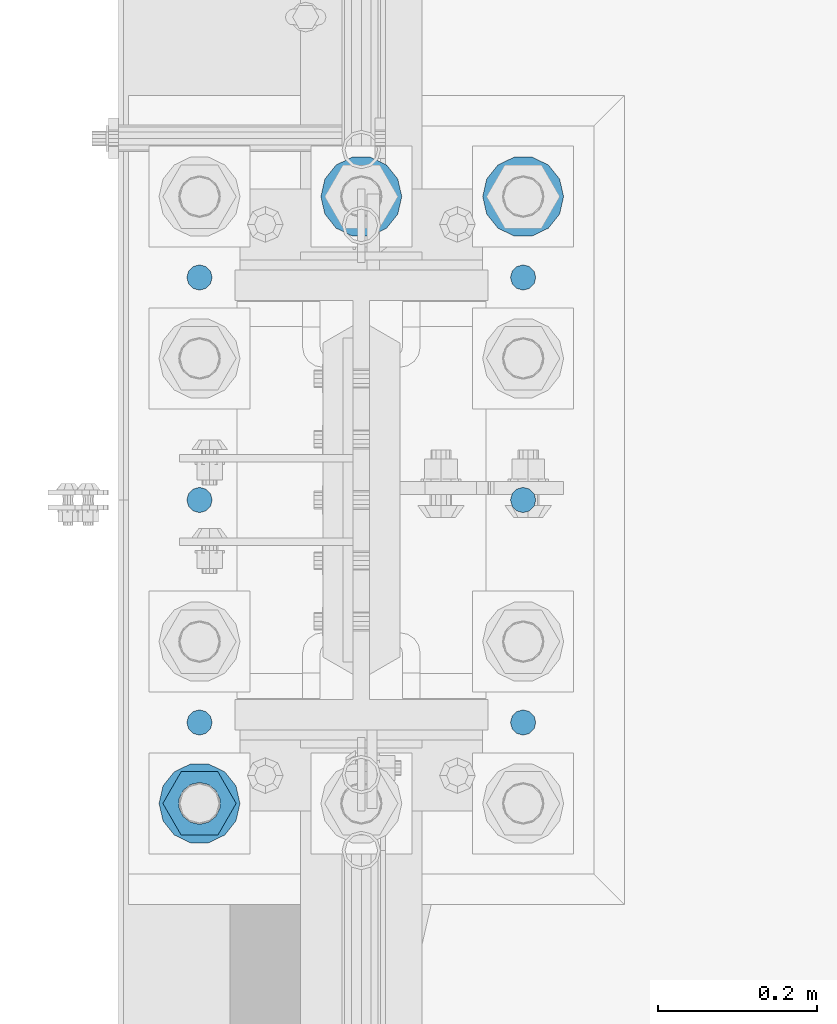
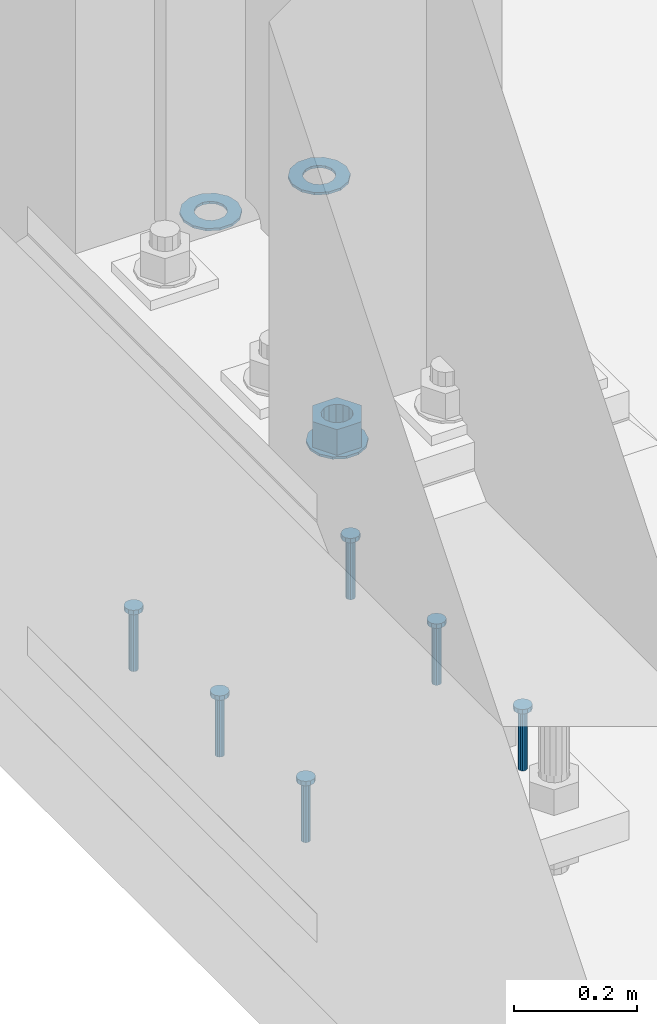
# One storey, part 845 of 1876: 10 columns, 1 element without a shape of its own.
"""IFC2X3 building model written with IfcOpenShell, lengths in millimetres."""

from ifc_helpers import new_model, si_unit, frame, origin_with_axes, place, context, subcontext, project, spatial, faceted_brep, material, type_object, element, aggregate, save


model = new_model("IFC2X3")

# Units and contexts
model_context = context("Model", 3, precision=1e-05, world=origin_with_axes())
body_context = subcontext(model_context, "Body", "Model", "MODEL_VIEW")
ifc_project = project(units=[si_unit("LENGTHUNIT", "METRE", prefix="MILLI"), si_unit("AREAUNIT", "SQUARE_METRE"), si_unit("VOLUMEUNIT", "CUBIC_METRE"), si_unit("MASSUNIT", "GRAM", prefix="KILO"), si_unit("TIMEUNIT", "SECOND"), si_unit("PLANEANGLEUNIT", "RADIAN"), si_unit("SOLIDANGLEUNIT", "STERADIAN"), si_unit("THERMODYNAMICTEMPERATUREUNIT", "DEGREE_CELSIUS"), si_unit("LUMINOUSINTENSITYUNIT", "LUMEN")], contexts=[model_context])

# Site, building, storey
site_placement = place(None, origin_with_axes())
site = spatial("IfcSite", under=ifc_project, at=site_placement, CompositionType="ELEMENT")
building_placement = place(site_placement, origin_with_axes())
building = spatial("IfcBuilding", under=site, at=building_placement, Name="Undefined", CompositionType="ELEMENT")
storey_placement = place(building_placement, origin_with_axes())
storey = spatial("IfcBuildingStorey", under=building, at=storey_placement, Name="Undefined", CompositionType="ELEMENT", Elevation=0.0)

# Assembly, columns
assembly_placement = place(storey_placement, origin_with_axes())
assembly = element("IfcElementAssembly", 1, at=assembly_placement, inside=storey, Name="TEMPLATE", AssemblyPlace="NOTDEFINED", PredefinedType="RIGID_FRAME")
ifc_material_1 = material(Name="STEEL/F436")
column_type_1 = type_object("IfcColumnType", Name="2_WASHER", PredefinedType="NOTDEFINED")
column_1_placement = place(assembly_placement, frame((0.0, 8001.0, 38.1), z_axis=(0.0, -1.0, 0.0), x_axis=(0.0, 0.0, -1.0)))
column_1 = element("IfcColumn", 2, at=column_1_placement, type_object=column_type_1, material=ifc_material_1, Name="WASHER", ObjectType="2_WASHER", context=body_context, shape_type="Brep", body=[
    faceted_brep([(0.0, -50.7999992370605, 9.09494701772928e-13), (0.0, -45.7692178020588, -22.0412936161442), (4.7625, -45.7692178020588, -22.0412936161442), (4.7625, -50.7999992370605, 9.09494701772928e-13), (0.0, -31.6732814587394, -39.7170387128856), (4.7625, -31.6732814587394, -39.7170387128856), (0.0, -11.3040632752118, -49.5263371950259), (4.7625, -11.3040632752118, -49.5263371950259), (0.0, 11.30406327521, -49.5263371950264), (4.7625, 11.30406327521, -49.5263371950264), (0.0, 31.6732814587385, -39.7170387128867), (4.7625, 31.6732814587385, -39.7170387128867), (0.0, 45.7692178020579, -22.041293616146), (4.7625, 45.7692178020579, -22.041293616146), (0.0, 50.7999992370605, -9.09494701772928e-13), (4.7625, 50.7999992370605, -9.09494701772928e-13), (0.0, 45.7692178020588, 22.0412936161442), (4.7625, 45.7692178020588, 22.0412936161442), (0.0, 31.6732814587394, 39.7170387128856), (4.7625, 31.6732814587394, 39.7170387128856), (0.0, 11.3040632752118, 49.5263371950259), (4.7625, 11.3040632752118, 49.5263371950259), (0.0, -11.30406327521, 49.5263371950264), (4.7625, -11.30406327521, 49.5263371950264), (0.0, -31.6732814587385, 39.7170387128867), (4.7625, -31.6732814587385, 39.7170387128867), (0.0, -45.7692178020579, 22.041293616146), (4.7625, -45.7692178020579, 22.041293616146), (0.0, 0.0, 26.9869995117188), (0.0, 11.7093983825444, 24.3146012721213), (4.7625, 11.7093983825444, 24.3146012721213), (4.7625, 0.0, 26.9869995117188), (0.0, 21.0996520289491, 16.8262864224157), (4.7625, 21.0996520289491, 16.8262864224157), (0.0, 26.3108629296712, 6.00524193584533), (4.7625, 26.3108629296712, 6.00524193584533), (0.0, 26.3108629296712, -6.00524193584533), (4.7625, 26.3108629296712, -6.00524193584533), (0.0, 21.0996520289491, -16.8262864224157), (4.7625, 21.0996520289491, -16.8262864224157), (0.0, 11.7093983825444, -24.3146012721213), (4.7625, 11.7093983825444, -24.3146012721213), (0.0, 0.0, -26.9869995117188), (4.7625, 0.0, -26.9869995117188), (0.0, -11.7093983825444, -24.3146012721213), (4.7625, -11.7093983825444, -24.3146012721213), (0.0, -21.0996520289491, -16.8262864224157), (4.7625, -21.0996520289491, -16.8262864224157), (0.0, -26.3108629296712, -6.00524193584533), (4.7625, -26.3108629296712, -6.00524193584533), (0.0, -26.3108629296712, 6.00524193584533), (4.7625, -26.3108629296712, 6.00524193584533), (0.0, -21.0996520289491, 16.8262864224157), (4.7625, -21.0996520289491, 16.8262864224157), (0.0, -11.7093983825444, 24.3146012721213), (4.7625, -11.7093983825444, 24.3146012721213)], [[[0, 1, 2, 3]], [[1, 4, 5, 2]], [[4, 6, 7, 5]], [[6, 8, 9, 7]], [[8, 10, 11, 9]], [[10, 12, 13, 11]], [[12, 14, 15, 13]], [[14, 16, 17, 15]], [[16, 18, 19, 17]], [[18, 20, 21, 19]], [[20, 22, 23, 21]], [[22, 24, 25, 23]], [[24, 26, 27, 25]], [[26, 0, 3, 27]], [[28, 29, 30, 31]], [[29, 32, 33, 30]], [[32, 34, 35, 33]], [[34, 36, 37, 35]], [[36, 38, 39, 37]], [[38, 40, 41, 39]], [[40, 42, 43, 41]], [[42, 44, 45, 43]], [[44, 46, 47, 45]], [[46, 48, 49, 47]], [[48, 50, 51, 49]], [[50, 52, 53, 51]], [[52, 54, 55, 53]], [[54, 28, 31, 55]], [[5, 7, 9, 11, 13, 15, 17, 19, 21, 23, 25, 27, 3, 2], [33, 35, 37, 39, 41, 43, 45, 47, 49, 51, 53, 55, 31, 30]], [[26, 24, 22, 20, 18, 16, 14, 12, 10, 8, 6, 4, 1, 0], [54, 52, 50, 48, 46, 44, 42, 40, 38, 36, 34, 32, 29, 28]]]),
])
column_2_placement = place(assembly_placement, frame((203.2, 8001.0, 38.1), z_axis=(0.0, 1.0, 0.0), x_axis=(0.0, 0.0, -1.0)))
column_2 = element("IfcColumn", 3, at=column_2_placement, type_object=column_type_1, material=ifc_material_1, Name="WASHER", ObjectType="2_WASHER", context=body_context, shape_type="Brep", body=[
    faceted_brep([(0.0, -50.7999992370605, 9.09494701772928e-13), (0.0, -45.7692178020588, -22.0412936161442), (4.7625, -45.7692178020588, -22.0412936161442), (4.7625, -50.7999992370605, 9.09494701772928e-13), (0.0, -31.6732814587394, -39.7170387128856), (4.7625, -31.6732814587394, -39.7170387128856), (0.0, -11.3040632752118, -49.5263371950259), (4.7625, -11.3040632752118, -49.5263371950259), (0.0, 11.30406327521, -49.5263371950264), (4.7625, 11.30406327521, -49.5263371950264), (0.0, 31.6732814587385, -39.7170387128867), (4.7625, 31.6732814587385, -39.7170387128867), (0.0, 45.7692178020579, -22.041293616146), (4.7625, 45.7692178020579, -22.041293616146), (0.0, 50.7999992370605, -9.09494701772928e-13), (4.7625, 50.7999992370605, -9.09494701772928e-13), (0.0, 45.7692178020588, 22.0412936161442), (4.7625, 45.7692178020588, 22.0412936161442), (0.0, 31.6732814587394, 39.7170387128856), (4.7625, 31.6732814587394, 39.7170387128856), (0.0, 11.3040632752118, 49.5263371950259), (4.7625, 11.3040632752118, 49.5263371950259), (0.0, -11.30406327521, 49.5263371950264), (4.7625, -11.30406327521, 49.5263371950264), (0.0, -31.6732814587385, 39.7170387128867), (4.7625, -31.6732814587385, 39.7170387128867), (0.0, -45.7692178020579, 22.041293616146), (4.7625, -45.7692178020579, 22.041293616146), (0.0, 0.0, 26.9869995117188), (0.0, 11.7093983825444, 24.3146012721213), (4.7625, 11.7093983825444, 24.3146012721213), (4.7625, 0.0, 26.9869995117188), (0.0, 21.0996520289491, 16.8262864224157), (4.7625, 21.0996520289491, 16.8262864224157), (0.0, 26.3108629296712, 6.00524193584533), (4.7625, 26.3108629296712, 6.00524193584533), (0.0, 26.3108629296712, -6.00524193584533), (4.7625, 26.3108629296712, -6.00524193584533), (0.0, 21.0996520289491, -16.8262864224157), (4.7625, 21.0996520289491, -16.8262864224157), (0.0, 11.7093983825444, -24.3146012721213), (4.7625, 11.7093983825444, -24.3146012721213), (0.0, 0.0, -26.9869995117188), (4.7625, 0.0, -26.9869995117188), (0.0, -11.7093983825444, -24.3146012721213), (4.7625, -11.7093983825444, -24.3146012721213), (0.0, -21.0996520289491, -16.8262864224157), (4.7625, -21.0996520289491, -16.8262864224157), (0.0, -26.3108629296712, -6.00524193584533), (4.7625, -26.3108629296712, -6.00524193584533), (0.0, -26.3108629296712, 6.00524193584533), (4.7625, -26.3108629296712, 6.00524193584533), (0.0, -21.0996520289491, 16.8262864224157), (4.7625, -21.0996520289491, 16.8262864224157), (0.0, -11.7093983825444, 24.3146012721213), (4.7625, -11.7093983825444, 24.3146012721213)], [[[0, 1, 2, 3]], [[1, 4, 5, 2]], [[4, 6, 7, 5]], [[6, 8, 9, 7]], [[8, 10, 11, 9]], [[10, 12, 13, 11]], [[12, 14, 15, 13]], [[14, 16, 17, 15]], [[16, 18, 19, 17]], [[18, 20, 21, 19]], [[20, 22, 23, 21]], [[22, 24, 25, 23]], [[24, 26, 27, 25]], [[26, 0, 3, 27]], [[28, 29, 30, 31]], [[29, 32, 33, 30]], [[32, 34, 35, 33]], [[34, 36, 37, 35]], [[36, 38, 39, 37]], [[38, 40, 41, 39]], [[40, 42, 43, 41]], [[42, 44, 45, 43]], [[44, 46, 47, 45]], [[46, 48, 49, 47]], [[48, 50, 51, 49]], [[50, 52, 53, 51]], [[52, 54, 55, 53]], [[54, 28, 31, 55]], [[5, 7, 9, 11, 13, 15, 17, 19, 21, 23, 25, 27, 3, 2], [33, 35, 37, 39, 41, 43, 45, 47, 49, 51, 53, 55, 31, 30]], [[26, 24, 22, 20, 18, 16, 14, 12, 10, 8, 6, 4, 1, 0], [54, 52, 50, 48, 46, 44, 42, 40, 38, 36, 34, 32, 29, 28]]]),
])
column_3_placement = place(assembly_placement, frame((-203.2, 7239.0, 119.0625), z_axis=(0.0, -1.0, 0.0), x_axis=(0.0, 0.0, -1.0)))
column_3 = element("IfcColumn", 4, at=column_3_placement, type_object=column_type_1, material=ifc_material_1, Name="WASHER", ObjectType="2_WASHER", context=body_context, shape_type="Brep", body=[
    faceted_brep([(0.0, -50.7999992370605, 9.09494701772928e-13), (0.0, -45.7692178020588, -22.0412936161442), (4.7625, -45.7692178020588, -22.0412936161442), (4.7625, -50.7999992370605, 9.09494701772928e-13), (0.0, -31.6732814587394, -39.7170387128856), (4.7625, -31.6732814587394, -39.7170387128856), (0.0, -11.3040632752118, -49.5263371950259), (4.7625, -11.3040632752118, -49.5263371950259), (0.0, 11.30406327521, -49.5263371950264), (4.7625, 11.30406327521, -49.5263371950264), (0.0, 31.6732814587385, -39.7170387128867), (4.7625, 31.6732814587385, -39.7170387128867), (0.0, 45.7692178020579, -22.041293616146), (4.7625, 45.7692178020579, -22.041293616146), (0.0, 50.7999992370605, -9.09494701772928e-13), (4.7625, 50.7999992370605, -9.09494701772928e-13), (0.0, 45.7692178020588, 22.0412936161442), (4.7625, 45.7692178020588, 22.0412936161442), (0.0, 31.6732814587394, 39.7170387128856), (4.7625, 31.6732814587394, 39.7170387128856), (0.0, 11.3040632752118, 49.5263371950259), (4.7625, 11.3040632752118, 49.5263371950259), (0.0, -11.30406327521, 49.5263371950264), (4.7625, -11.30406327521, 49.5263371950264), (0.0, -31.6732814587385, 39.7170387128867), (4.7625, -31.6732814587385, 39.7170387128867), (0.0, -45.7692178020579, 22.041293616146), (4.7625, -45.7692178020579, 22.041293616146), (0.0, 0.0, 26.9869995117188), (0.0, 11.7093983825444, 24.3146012721213), (4.7625, 11.7093983825444, 24.3146012721213), (4.7625, 0.0, 26.9869995117188), (0.0, 21.0996520289491, 16.8262864224157), (4.7625, 21.0996520289491, 16.8262864224157), (0.0, 26.3108629296712, 6.00524193584533), (4.7625, 26.3108629296712, 6.00524193584533), (0.0, 26.3108629296712, -6.00524193584533), (4.7625, 26.3108629296712, -6.00524193584533), (0.0, 21.0996520289491, -16.8262864224157), (4.7625, 21.0996520289491, -16.8262864224157), (0.0, 11.7093983825444, -24.3146012721213), (4.7625, 11.7093983825444, -24.3146012721213), (0.0, 0.0, -26.9869995117188), (4.7625, 0.0, -26.9869995117188), (0.0, -11.7093983825444, -24.3146012721213), (4.7625, -11.7093983825444, -24.3146012721213), (0.0, -21.0996520289491, -16.8262864224157), (4.7625, -21.0996520289491, -16.8262864224157), (0.0, -26.3108629296712, -6.00524193584533), (4.7625, -26.3108629296712, -6.00524193584533), (0.0, -26.3108629296712, 6.00524193584533), (4.7625, -26.3108629296712, 6.00524193584533), (0.0, -21.0996520289491, 16.8262864224157), (4.7625, -21.0996520289491, 16.8262864224157), (0.0, -11.7093983825444, 24.3146012721213), (4.7625, -11.7093983825444, 24.3146012721213)], [[[0, 1, 2, 3]], [[1, 4, 5, 2]], [[4, 6, 7, 5]], [[6, 8, 9, 7]], [[8, 10, 11, 9]], [[10, 12, 13, 11]], [[12, 14, 15, 13]], [[14, 16, 17, 15]], [[16, 18, 19, 17]], [[18, 20, 21, 19]], [[20, 22, 23, 21]], [[22, 24, 25, 23]], [[24, 26, 27, 25]], [[26, 0, 3, 27]], [[28, 29, 30, 31]], [[29, 32, 33, 30]], [[32, 34, 35, 33]], [[34, 36, 37, 35]], [[36, 38, 39, 37]], [[38, 40, 41, 39]], [[40, 42, 43, 41]], [[42, 44, 45, 43]], [[44, 46, 47, 45]], [[46, 48, 49, 47]], [[48, 50, 51, 49]], [[50, 52, 53, 51]], [[52, 54, 55, 53]], [[54, 28, 31, 55]], [[5, 7, 9, 11, 13, 15, 17, 19, 21, 23, 25, 27, 3, 2], [33, 35, 37, 39, 41, 43, 45, 47, 49, 51, 53, 55, 31, 30]], [[26, 24, 22, 20, 18, 16, 14, 12, 10, 8, 6, 4, 1, 0], [54, 52, 50, 48, 46, 44, 42, 40, 38, 36, 34, 32, 29, 28]]]),
])
ifc_material_2 = material(Name="STEEL/A108")
column_type_2 = type_object("IfcColumnType", Name="5/8-DIA_HEADED ANCHOR STUD", PredefinedType="NOTDEFINED")
column_4_placement = place(assembly_placement, frame((203.2, 7899.4, -736.6), z_axis=(1.0, 0.0, 0.0), x_axis=(0.0, 0.0, 1.0)))
column_4 = element("IfcColumn", 5, at=column_4_placement, type_object=column_type_2, material=ifc_material_2, Name="HEADED ANCHOR STUD", ObjectType="5/8-DIA_HEADED ANCHOR STUD", context=body_context, shape_type="Brep", body=[
    faceted_brep([(0.0, -7.94000005722046, 0.0), (0.0, -6.86999988555908, -3.97000002861023), (116.84, -6.86999988555908, -3.97000002861023), (116.84, -7.94000005722046, 0.0), (0.0, -3.97000002861023, -6.86999988555908), (116.84, -3.97000002861023, -6.86999988555908), (0.0, 0.0, -7.94000005722046), (116.84, 0.0, -7.94000005722046), (0.0, 3.97000002861023, -6.86999988555908), (116.84, 3.97000002861023, -6.86999988555908), (0.0, 6.86999988555908, -3.97000002861023), (116.84, 6.86999988555908, -3.97000002861023), (0.0, 7.94000005722046, 0.0), (116.84, 7.94000005722046, 0.0), (0.0, 6.86999988555908, 3.97000002861023), (116.84, 6.86999988555908, 3.97000002861023), (0.0, 3.97000002861023, 6.86999988555908), (116.84, 3.97000002861023, 6.86999988555908), (0.0, 0.0, 7.94000005722046), (116.84, 0.0, 7.94000005722046), (0.0, -3.97000002861023, 6.86999988555908), (116.84, -3.97000002861023, 6.86999988555908), (0.0, -6.86999988555908, 3.97000002861023), (116.84, -6.86999988555908, 3.97000002861023), (118.11, -13.75, -7.94000005722046), (118.11, -15.8800001144409, 0.0), (118.11, -7.94000005722046, -13.75), (118.11, 0.0, -15.8800001144409), (118.11, 7.94000005722046, -13.75), (118.11, 13.75, -7.94000005722046), (118.11, 15.8800001144409, 0.0), (118.11, 13.75, 7.94000005722046), (118.11, 7.94000005722046, 13.75), (118.11, 0.0, 15.8800001144409), (118.11, -7.94000005722046, 13.75), (118.11, -13.75, 7.94000005722046), (127.0, -13.75, -7.94000005722046), (127.0, -15.8800001144409, 0.0), (127.0, -7.94000005722046, -13.75), (127.0, 0.0, -15.8800001144409), (127.0, 7.94000005722046, -13.75), (127.0, 13.75, -7.94000005722046), (127.0, 15.8800001144409, 0.0), (127.0, 13.75, 7.94000005722046), (127.0, 7.94000005722046, 13.75), (127.0, 0.0, 15.8800001144409), (127.0, -7.94000005722046, 13.75), (127.0, -13.75, 7.94000005722046)], [[[0, 1, 2, 3]], [[1, 4, 5, 2]], [[4, 6, 7, 5]], [[6, 8, 9, 7]], [[8, 10, 11, 9]], [[10, 12, 13, 11]], [[12, 14, 15, 13]], [[14, 16, 17, 15]], [[16, 18, 19, 17]], [[18, 20, 21, 19]], [[20, 22, 23, 21]], [[22, 0, 3, 23]], [[22, 20, 18, 16, 14, 12, 10, 8, 6, 4, 1, 0]], [[3, 2, 24, 25]], [[2, 5, 26, 24]], [[5, 7, 27, 26]], [[7, 9, 28, 27]], [[9, 11, 29, 28]], [[11, 13, 30, 29]], [[13, 15, 31, 30]], [[15, 17, 32, 31]], [[17, 19, 33, 32]], [[19, 21, 34, 33]], [[21, 23, 35, 34]], [[23, 3, 25, 35]], [[25, 24, 36, 37]], [[24, 26, 38, 36]], [[26, 27, 39, 38]], [[27, 28, 40, 39]], [[28, 29, 41, 40]], [[29, 30, 42, 41]], [[30, 31, 43, 42]], [[31, 32, 44, 43]], [[32, 33, 45, 44]], [[33, 34, 46, 45]], [[34, 35, 47, 46]], [[35, 25, 37, 47]], [[38, 39, 40, 41, 42, 43, 44, 45, 46, 47, 37, 36]]]),
])
column_5_placement = place(assembly_placement, frame((203.2, 7340.6, -736.6), z_axis=(1.0, 0.0, 0.0), x_axis=(0.0, 0.0, 1.0)))
column_5 = element("IfcColumn", 6, at=column_5_placement, type_object=column_type_2, material=ifc_material_2, Name="HEADED ANCHOR STUD", ObjectType="5/8-DIA_HEADED ANCHOR STUD", context=body_context, shape_type="Brep", body=[
    faceted_brep([(0.0, -7.94000005722046, 0.0), (0.0, -6.86999988555908, -3.97000002861023), (116.84, -6.86999988555908, -3.97000002861023), (116.84, -7.94000005722046, 0.0), (0.0, -3.97000002861023, -6.86999988555908), (116.84, -3.97000002861023, -6.86999988555908), (0.0, 0.0, -7.94000005722046), (116.84, 0.0, -7.94000005722046), (0.0, 3.97000002861023, -6.86999988555908), (116.84, 3.97000002861023, -6.86999988555908), (0.0, 6.86999988555908, -3.97000002861023), (116.84, 6.86999988555908, -3.97000002861023), (0.0, 7.94000005722046, 0.0), (116.84, 7.94000005722046, 0.0), (0.0, 6.86999988555908, 3.97000002861023), (116.84, 6.86999988555908, 3.97000002861023), (0.0, 3.97000002861023, 6.86999988555908), (116.84, 3.97000002861023, 6.86999988555908), (0.0, 0.0, 7.94000005722046), (116.84, 0.0, 7.94000005722046), (0.0, -3.97000002861023, 6.86999988555908), (116.84, -3.97000002861023, 6.86999988555908), (0.0, -6.86999988555908, 3.97000002861023), (116.84, -6.86999988555908, 3.97000002861023), (118.11, -13.75, -7.94000005722046), (118.11, -15.8800001144409, 0.0), (118.11, -7.94000005722046, -13.75), (118.11, 0.0, -15.8800001144409), (118.11, 7.94000005722046, -13.75), (118.11, 13.75, -7.94000005722046), (118.11, 15.8800001144409, 0.0), (118.11, 13.75, 7.94000005722046), (118.11, 7.94000005722046, 13.75), (118.11, 0.0, 15.8800001144409), (118.11, -7.94000005722046, 13.75), (118.11, -13.75, 7.94000005722046), (127.0, -13.75, -7.94000005722046), (127.0, -15.8800001144409, 0.0), (127.0, -7.94000005722046, -13.75), (127.0, 0.0, -15.8800001144409), (127.0, 7.94000005722046, -13.75), (127.0, 13.75, -7.94000005722046), (127.0, 15.8800001144409, 0.0), (127.0, 13.75, 7.94000005722046), (127.0, 7.94000005722046, 13.75), (127.0, 0.0, 15.8800001144409), (127.0, -7.94000005722046, 13.75), (127.0, -13.75, 7.94000005722046)], [[[0, 1, 2, 3]], [[1, 4, 5, 2]], [[4, 6, 7, 5]], [[6, 8, 9, 7]], [[8, 10, 11, 9]], [[10, 12, 13, 11]], [[12, 14, 15, 13]], [[14, 16, 17, 15]], [[16, 18, 19, 17]], [[18, 20, 21, 19]], [[20, 22, 23, 21]], [[22, 0, 3, 23]], [[22, 20, 18, 16, 14, 12, 10, 8, 6, 4, 1, 0]], [[3, 2, 24, 25]], [[2, 5, 26, 24]], [[5, 7, 27, 26]], [[7, 9, 28, 27]], [[9, 11, 29, 28]], [[11, 13, 30, 29]], [[13, 15, 31, 30]], [[15, 17, 32, 31]], [[17, 19, 33, 32]], [[19, 21, 34, 33]], [[21, 23, 35, 34]], [[23, 3, 25, 35]], [[25, 24, 36, 37]], [[24, 26, 38, 36]], [[26, 27, 39, 38]], [[27, 28, 40, 39]], [[28, 29, 41, 40]], [[29, 30, 42, 41]], [[30, 31, 43, 42]], [[31, 32, 44, 43]], [[32, 33, 45, 44]], [[33, 34, 46, 45]], [[34, 35, 47, 46]], [[35, 25, 37, 47]], [[38, 39, 40, 41, 42, 43, 44, 45, 46, 47, 37, 36]]]),
])
column_6_placement = place(assembly_placement, frame((203.2, 7620.0, -736.6), z_axis=(1.0, 0.0, 0.0), x_axis=(0.0, 0.0, 1.0)))
column_6 = element("IfcColumn", 7, at=column_6_placement, type_object=column_type_2, material=ifc_material_2, Name="HEADED ANCHOR STUD", ObjectType="5/8-DIA_HEADED ANCHOR STUD", context=body_context, shape_type="Brep", body=[
    faceted_brep([(0.0, -7.94000005722046, 0.0), (0.0, -6.86999988555908, -3.97000002861023), (116.84, -6.86999988555908, -3.97000002861023), (116.84, -7.94000005722046, 0.0), (0.0, -3.97000002861023, -6.86999988555908), (116.84, -3.97000002861023, -6.86999988555908), (0.0, 0.0, -7.94000005722046), (116.84, 0.0, -7.94000005722046), (0.0, 3.97000002861023, -6.86999988555908), (116.84, 3.97000002861023, -6.86999988555908), (0.0, 6.86999988555908, -3.97000002861023), (116.84, 6.86999988555908, -3.97000002861023), (0.0, 7.94000005722046, 0.0), (116.84, 7.94000005722046, 0.0), (0.0, 6.86999988555908, 3.97000002861023), (116.84, 6.86999988555908, 3.97000002861023), (0.0, 3.97000002861023, 6.86999988555908), (116.84, 3.97000002861023, 6.86999988555908), (0.0, 0.0, 7.94000005722046), (116.84, 0.0, 7.94000005722046), (0.0, -3.97000002861023, 6.86999988555908), (116.84, -3.97000002861023, 6.86999988555908), (0.0, -6.86999988555908, 3.97000002861023), (116.84, -6.86999988555908, 3.97000002861023), (118.11, -13.75, -7.94000005722046), (118.11, -15.8800001144409, 0.0), (118.11, -7.94000005722046, -13.75), (118.11, 0.0, -15.8800001144409), (118.11, 7.94000005722046, -13.75), (118.11, 13.75, -7.94000005722046), (118.11, 15.8800001144409, 0.0), (118.11, 13.75, 7.94000005722046), (118.11, 7.94000005722046, 13.75), (118.11, 0.0, 15.8800001144409), (118.11, -7.94000005722046, 13.75), (118.11, -13.75, 7.94000005722046), (127.0, -13.75, -7.94000005722046), (127.0, -15.8800001144409, 0.0), (127.0, -7.94000005722046, -13.75), (127.0, 0.0, -15.8800001144409), (127.0, 7.94000005722046, -13.75), (127.0, 13.75, -7.94000005722046), (127.0, 15.8800001144409, 0.0), (127.0, 13.75, 7.94000005722046), (127.0, 7.94000005722046, 13.75), (127.0, 0.0, 15.8800001144409), (127.0, -7.94000005722046, 13.75), (127.0, -13.75, 7.94000005722046)], [[[0, 1, 2, 3]], [[1, 4, 5, 2]], [[4, 6, 7, 5]], [[6, 8, 9, 7]], [[8, 10, 11, 9]], [[10, 12, 13, 11]], [[12, 14, 15, 13]], [[14, 16, 17, 15]], [[16, 18, 19, 17]], [[18, 20, 21, 19]], [[20, 22, 23, 21]], [[22, 0, 3, 23]], [[22, 20, 18, 16, 14, 12, 10, 8, 6, 4, 1, 0]], [[3, 2, 24, 25]], [[2, 5, 26, 24]], [[5, 7, 27, 26]], [[7, 9, 28, 27]], [[9, 11, 29, 28]], [[11, 13, 30, 29]], [[13, 15, 31, 30]], [[15, 17, 32, 31]], [[17, 19, 33, 32]], [[19, 21, 34, 33]], [[21, 23, 35, 34]], [[23, 3, 25, 35]], [[25, 24, 36, 37]], [[24, 26, 38, 36]], [[26, 27, 39, 38]], [[27, 28, 40, 39]], [[28, 29, 41, 40]], [[29, 30, 42, 41]], [[30, 31, 43, 42]], [[31, 32, 44, 43]], [[32, 33, 45, 44]], [[33, 34, 46, 45]], [[34, 35, 47, 46]], [[35, 25, 37, 47]], [[38, 39, 40, 41, 42, 43, 44, 45, 46, 47, 37, 36]]]),
])
column_7_placement = place(assembly_placement, frame((-203.2, 7899.4, -736.6), z_axis=(1.0, 0.0, 0.0), x_axis=(0.0, 0.0, 1.0)))
column_7 = element("IfcColumn", 8, at=column_7_placement, type_object=column_type_2, material=ifc_material_2, Name="HEADED ANCHOR STUD", ObjectType="5/8-DIA_HEADED ANCHOR STUD", context=body_context, shape_type="Brep", body=[
    faceted_brep([(0.0, -7.94000005722046, 0.0), (0.0, -6.86999988555908, -3.97000002861023), (116.84, -6.86999988555908, -3.97000002861023), (116.84, -7.94000005722046, 0.0), (0.0, -3.97000002861023, -6.86999988555908), (116.84, -3.97000002861023, -6.86999988555908), (0.0, 0.0, -7.94000005722046), (116.84, 0.0, -7.94000005722046), (0.0, 3.97000002861023, -6.86999988555908), (116.84, 3.97000002861023, -6.86999988555908), (0.0, 6.86999988555908, -3.97000002861023), (116.84, 6.86999988555908, -3.97000002861023), (0.0, 7.94000005722046, 0.0), (116.84, 7.94000005722046, 0.0), (0.0, 6.86999988555908, 3.97000002861023), (116.84, 6.86999988555908, 3.97000002861023), (0.0, 3.97000002861023, 6.86999988555908), (116.84, 3.97000002861023, 6.86999988555908), (0.0, 0.0, 7.94000005722046), (116.84, 0.0, 7.94000005722046), (0.0, -3.97000002861023, 6.86999988555908), (116.84, -3.97000002861023, 6.86999988555908), (0.0, -6.86999988555908, 3.97000002861023), (116.84, -6.86999988555908, 3.97000002861023), (118.11, -13.75, -7.94000005722046), (118.11, -15.8800001144409, 0.0), (118.11, -7.94000005722046, -13.75), (118.11, 0.0, -15.8800001144409), (118.11, 7.94000005722046, -13.75), (118.11, 13.75, -7.94000005722046), (118.11, 15.8800001144409, 0.0), (118.11, 13.75, 7.94000005722046), (118.11, 7.94000005722046, 13.75), (118.11, 0.0, 15.8800001144409), (118.11, -7.94000005722046, 13.75), (118.11, -13.75, 7.94000005722046), (127.0, -13.75, -7.94000005722046), (127.0, -15.8800001144409, 0.0), (127.0, -7.94000005722046, -13.75), (127.0, 0.0, -15.8800001144409), (127.0, 7.94000005722046, -13.75), (127.0, 13.75, -7.94000005722046), (127.0, 15.8800001144409, 0.0), (127.0, 13.75, 7.94000005722046), (127.0, 7.94000005722046, 13.75), (127.0, 0.0, 15.8800001144409), (127.0, -7.94000005722046, 13.75), (127.0, -13.75, 7.94000005722046)], [[[0, 1, 2, 3]], [[1, 4, 5, 2]], [[4, 6, 7, 5]], [[6, 8, 9, 7]], [[8, 10, 11, 9]], [[10, 12, 13, 11]], [[12, 14, 15, 13]], [[14, 16, 17, 15]], [[16, 18, 19, 17]], [[18, 20, 21, 19]], [[20, 22, 23, 21]], [[22, 0, 3, 23]], [[22, 20, 18, 16, 14, 12, 10, 8, 6, 4, 1, 0]], [[3, 2, 24, 25]], [[2, 5, 26, 24]], [[5, 7, 27, 26]], [[7, 9, 28, 27]], [[9, 11, 29, 28]], [[11, 13, 30, 29]], [[13, 15, 31, 30]], [[15, 17, 32, 31]], [[17, 19, 33, 32]], [[19, 21, 34, 33]], [[21, 23, 35, 34]], [[23, 3, 25, 35]], [[25, 24, 36, 37]], [[24, 26, 38, 36]], [[26, 27, 39, 38]], [[27, 28, 40, 39]], [[28, 29, 41, 40]], [[29, 30, 42, 41]], [[30, 31, 43, 42]], [[31, 32, 44, 43]], [[32, 33, 45, 44]], [[33, 34, 46, 45]], [[34, 35, 47, 46]], [[35, 25, 37, 47]], [[38, 39, 40, 41, 42, 43, 44, 45, 46, 47, 37, 36]]]),
])
column_8_placement = place(assembly_placement, frame((-203.2, 7340.6, -736.6), z_axis=(1.0, 0.0, 0.0), x_axis=(0.0, 0.0, 1.0)))
column_8 = element("IfcColumn", 9, at=column_8_placement, type_object=column_type_2, material=ifc_material_2, Name="HEADED ANCHOR STUD", ObjectType="5/8-DIA_HEADED ANCHOR STUD", context=body_context, shape_type="Brep", body=[
    faceted_brep([(0.0, -7.94000005722046, 0.0), (0.0, -6.86999988555908, -3.97000002861023), (116.84, -6.86999988555908, -3.97000002861023), (116.84, -7.94000005722046, 0.0), (0.0, -3.97000002861023, -6.86999988555908), (116.84, -3.97000002861023, -6.86999988555908), (0.0, 0.0, -7.94000005722046), (116.84, 0.0, -7.94000005722046), (0.0, 3.97000002861023, -6.86999988555908), (116.84, 3.97000002861023, -6.86999988555908), (0.0, 6.86999988555908, -3.97000002861023), (116.84, 6.86999988555908, -3.97000002861023), (0.0, 7.94000005722046, 0.0), (116.84, 7.94000005722046, 0.0), (0.0, 6.86999988555908, 3.97000002861023), (116.84, 6.86999988555908, 3.97000002861023), (0.0, 3.97000002861023, 6.86999988555908), (116.84, 3.97000002861023, 6.86999988555908), (0.0, 0.0, 7.94000005722046), (116.84, 0.0, 7.94000005722046), (0.0, -3.97000002861023, 6.86999988555908), (116.84, -3.97000002861023, 6.86999988555908), (0.0, -6.86999988555908, 3.97000002861023), (116.84, -6.86999988555908, 3.97000002861023), (118.11, -13.75, -7.94000005722046), (118.11, -15.8800001144409, 0.0), (118.11, -7.94000005722046, -13.75), (118.11, 0.0, -15.8800001144409), (118.11, 7.94000005722046, -13.75), (118.11, 13.75, -7.94000005722046), (118.11, 15.8800001144409, 0.0), (118.11, 13.75, 7.94000005722046), (118.11, 7.94000005722046, 13.75), (118.11, 0.0, 15.8800001144409), (118.11, -7.94000005722046, 13.75), (118.11, -13.75, 7.94000005722046), (127.0, -13.75, -7.94000005722046), (127.0, -15.8800001144409, 0.0), (127.0, -7.94000005722046, -13.75), (127.0, 0.0, -15.8800001144409), (127.0, 7.94000005722046, -13.75), (127.0, 13.75, -7.94000005722046), (127.0, 15.8800001144409, 0.0), (127.0, 13.75, 7.94000005722046), (127.0, 7.94000005722046, 13.75), (127.0, 0.0, 15.8800001144409), (127.0, -7.94000005722046, 13.75), (127.0, -13.75, 7.94000005722046)], [[[0, 1, 2, 3]], [[1, 4, 5, 2]], [[4, 6, 7, 5]], [[6, 8, 9, 7]], [[8, 10, 11, 9]], [[10, 12, 13, 11]], [[12, 14, 15, 13]], [[14, 16, 17, 15]], [[16, 18, 19, 17]], [[18, 20, 21, 19]], [[20, 22, 23, 21]], [[22, 0, 3, 23]], [[22, 20, 18, 16, 14, 12, 10, 8, 6, 4, 1, 0]], [[3, 2, 24, 25]], [[2, 5, 26, 24]], [[5, 7, 27, 26]], [[7, 9, 28, 27]], [[9, 11, 29, 28]], [[11, 13, 30, 29]], [[13, 15, 31, 30]], [[15, 17, 32, 31]], [[17, 19, 33, 32]], [[19, 21, 34, 33]], [[21, 23, 35, 34]], [[23, 3, 25, 35]], [[25, 24, 36, 37]], [[24, 26, 38, 36]], [[26, 27, 39, 38]], [[27, 28, 40, 39]], [[28, 29, 41, 40]], [[29, 30, 42, 41]], [[30, 31, 43, 42]], [[31, 32, 44, 43]], [[32, 33, 45, 44]], [[33, 34, 46, 45]], [[34, 35, 47, 46]], [[35, 25, 37, 47]], [[38, 39, 40, 41, 42, 43, 44, 45, 46, 47, 37, 36]]]),
])
column_9_placement = place(assembly_placement, frame((-203.2, 7620.0, -736.6), z_axis=(1.0, 0.0, 0.0), x_axis=(0.0, 0.0, 1.0)))
column_9 = element("IfcColumn", 10, at=column_9_placement, type_object=column_type_2, material=ifc_material_2, Name="HEADED ANCHOR STUD", ObjectType="5/8-DIA_HEADED ANCHOR STUD", context=body_context, shape_type="Brep", body=[
    faceted_brep([(0.0, -7.94000005722046, 0.0), (0.0, -6.86999988555908, -3.97000002861023), (116.84, -6.86999988555908, -3.97000002861023), (116.84, -7.94000005722046, 0.0), (0.0, -3.97000002861023, -6.86999988555908), (116.84, -3.97000002861023, -6.86999988555908), (0.0, 0.0, -7.94000005722046), (116.84, 0.0, -7.94000005722046), (0.0, 3.97000002861023, -6.86999988555908), (116.84, 3.97000002861023, -6.86999988555908), (0.0, 6.86999988555908, -3.97000002861023), (116.84, 6.86999988555908, -3.97000002861023), (0.0, 7.94000005722046, 0.0), (116.84, 7.94000005722046, 0.0), (0.0, 6.86999988555908, 3.97000002861023), (116.84, 6.86999988555908, 3.97000002861023), (0.0, 3.97000002861023, 6.86999988555908), (116.84, 3.97000002861023, 6.86999988555908), (0.0, 0.0, 7.94000005722046), (116.84, 0.0, 7.94000005722046), (0.0, -3.97000002861023, 6.86999988555908), (116.84, -3.97000002861023, 6.86999988555908), (0.0, -6.86999988555908, 3.97000002861023), (116.84, -6.86999988555908, 3.97000002861023), (118.11, -13.75, -7.94000005722046), (118.11, -15.8800001144409, 0.0), (118.11, -7.94000005722046, -13.75), (118.11, 0.0, -15.8800001144409), (118.11, 7.94000005722046, -13.75), (118.11, 13.75, -7.94000005722046), (118.11, 15.8800001144409, 0.0), (118.11, 13.75, 7.94000005722046), (118.11, 7.94000005722046, 13.75), (118.11, 0.0, 15.8800001144409), (118.11, -7.94000005722046, 13.75), (118.11, -13.75, 7.94000005722046), (127.0, -13.75, -7.94000005722046), (127.0, -15.8800001144409, 0.0), (127.0, -7.94000005722046, -13.75), (127.0, 0.0, -15.8800001144409), (127.0, 7.94000005722046, -13.75), (127.0, 13.75, -7.94000005722046), (127.0, 15.8800001144409, 0.0), (127.0, 13.75, 7.94000005722046), (127.0, 7.94000005722046, 13.75), (127.0, 0.0, 15.8800001144409), (127.0, -7.94000005722046, 13.75), (127.0, -13.75, 7.94000005722046)], [[[0, 1, 2, 3]], [[1, 4, 5, 2]], [[4, 6, 7, 5]], [[6, 8, 9, 7]], [[8, 10, 11, 9]], [[10, 12, 13, 11]], [[12, 14, 15, 13]], [[14, 16, 17, 15]], [[16, 18, 19, 17]], [[18, 20, 21, 19]], [[20, 22, 23, 21]], [[22, 0, 3, 23]], [[22, 20, 18, 16, 14, 12, 10, 8, 6, 4, 1, 0]], [[3, 2, 24, 25]], [[2, 5, 26, 24]], [[5, 7, 27, 26]], [[7, 9, 28, 27]], [[9, 11, 29, 28]], [[11, 13, 30, 29]], [[13, 15, 31, 30]], [[15, 17, 32, 31]], [[17, 19, 33, 32]], [[19, 21, 34, 33]], [[21, 23, 35, 34]], [[23, 3, 25, 35]], [[25, 24, 36, 37]], [[24, 26, 38, 36]], [[26, 27, 39, 38]], [[27, 28, 40, 39]], [[28, 29, 41, 40]], [[29, 30, 42, 41]], [[30, 31, 43, 42]], [[31, 32, 44, 43]], [[32, 33, 45, 44]], [[33, 34, 46, 45]], [[34, 35, 47, 46]], [[35, 25, 37, 47]], [[38, 39, 40, 41, 42, 43, 44, 45, 46, 47, 37, 36]]]),
])
ifc_material_3 = material(Name="STEEL/A563")
column_type_3 = type_object("IfcColumnType", Name="2_HEAVY_HEX_NUT", PredefinedType="NOTDEFINED")
column_10_placement = place(assembly_placement, frame((-203.2, 7239.0, 169.8625), z_axis=(0.0, -1.0, 0.0), x_axis=(0.0, 0.0, -1.0)))
column_10 = element("IfcColumn", 11, at=column_10_placement, type_object=column_type_3, material=ifc_material_3, Name="NUT", ObjectType="2_HEAVY_HEX_NUT", context=body_context, shape_type="Brep", body=[
    faceted_brep([(0.0, -46.0369987487793, 9.09494701772928e-13), (0.0, -23.0184993743896, -39.869213104248), (50.8, -23.0184993743896, -39.869213104248), (50.8, -46.0369987487793, 9.09494701772928e-13), (0.0, 23.0184993743896, -39.869213104248), (50.8, 23.0184993743896, -39.869213104248), (0.0, 46.0369987487793, -9.09494701772928e-13), (50.8, 46.0369987487793, -9.09494701772928e-13), (0.0, 23.0184993743896, 39.869213104248), (50.8, 23.0184993743896, 39.869213104248), (0.0, -23.0184993743896, 39.869213104248), (50.8, -23.0184993743896, 39.869213104248), (0.0, 0.0, 26.1940002441406), (0.0, 11.3650617044514, 23.5999013092769), (50.8, 11.3650617044513, 23.5999013092771), (50.8, 0.0, 26.1940002441406), (0.0, 20.4791109456437, 16.3316083006703), (50.8, 20.4791109456439, 16.3316083006703), (0.0, 25.5370200498346, 5.82867859874477), (50.8, 25.5370200498343, 5.82867859874455), (0.0, 25.5370200498346, -5.82867859874477), (50.8, 25.5370200498343, -5.82867859874455), (0.0, 20.4791109456437, -16.3316083006703), (50.8, 20.4791109456439, -16.3316083006703), (0.0, 11.3650617044514, -23.5999013092769), (50.8, 11.3650617044514, -23.5999013092771), (0.0, 0.0, -26.1940002441406), (50.8, 0.0, -26.1940002441406), (0.0, -11.3650617044514, -23.5999013092769), (50.8, -11.3650617044513, -23.5999013092771), (0.0, -20.4791109456437, -16.3316083006703), (50.8, -20.4791109456439, -16.3316083006703), (0.0, -25.5370200498346, -5.82867859874477), (50.8, -25.5370200498343, -5.82867859874455), (0.0, -25.5370200498346, 5.82867859874477), (50.8, -25.5370200498343, 5.82867859874455), (0.0, -20.4791109456437, 16.3316083006703), (50.8, -20.4791109456439, 16.3316083006703), (0.0, -11.3650617044514, 23.5999013092769), (50.8, -11.3650617044514, 23.5999013092771)], [[[0, 1, 2, 3]], [[1, 4, 5, 2]], [[4, 6, 7, 5]], [[6, 8, 9, 7]], [[8, 10, 11, 9]], [[10, 0, 3, 11]], [[12, 13, 14, 15]], [[13, 16, 17, 14]], [[16, 18, 19, 17]], [[18, 20, 21, 19]], [[20, 22, 23, 21]], [[22, 24, 25, 23]], [[24, 26, 27, 25]], [[26, 28, 29, 27]], [[28, 30, 31, 29]], [[30, 32, 33, 31]], [[32, 34, 35, 33]], [[34, 36, 37, 35]], [[36, 38, 39, 37]], [[38, 12, 15, 39]], [[5, 7, 9, 11, 3, 2], [17, 19, 21, 23, 25, 27, 29, 31, 33, 35, 37, 39, 15, 14]], [[10, 8, 6, 4, 1, 0], [38, 36, 34, 32, 30, 28, 26, 24, 22, 20, 18, 16, 13, 12]]]),
])
aggregate(assembly, [column_1, column_2, column_4, column_5, column_6, column_7, column_8, column_9, column_10, column_3])

save(model, "model.ifc")
